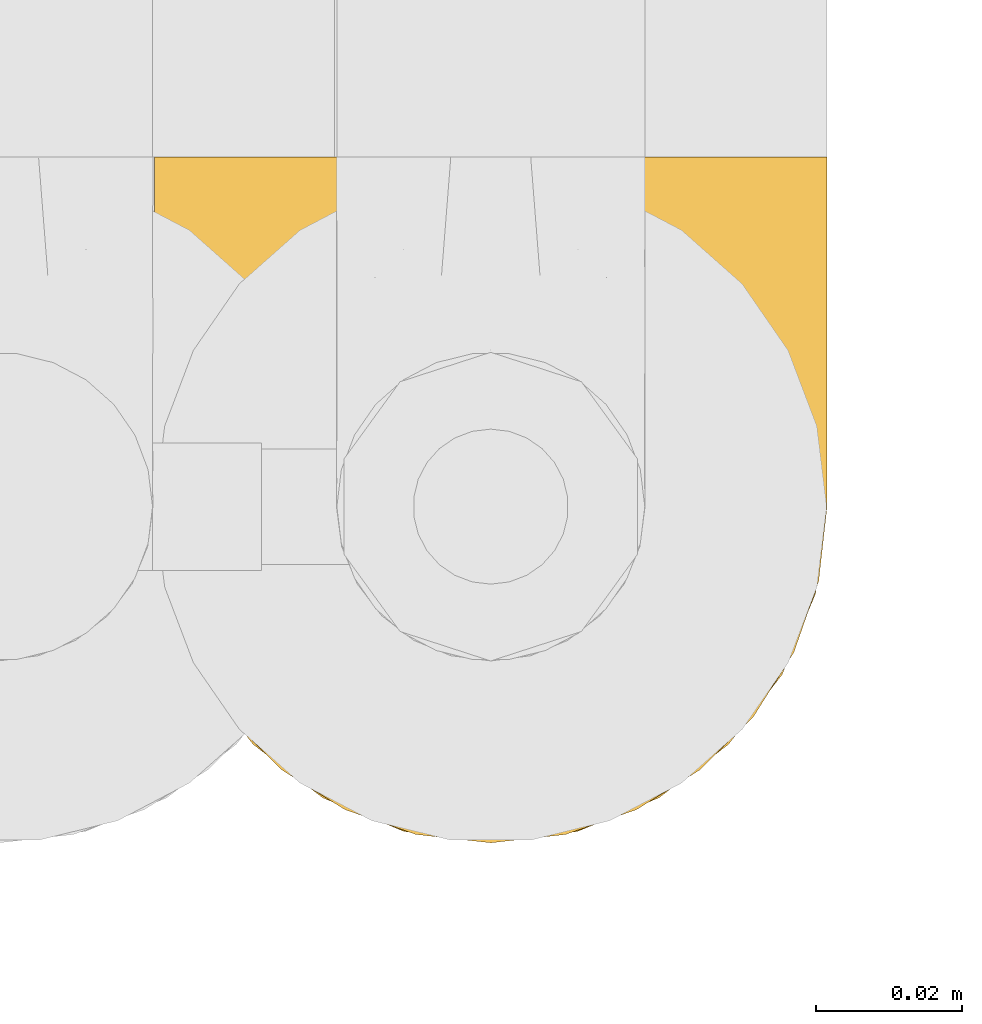
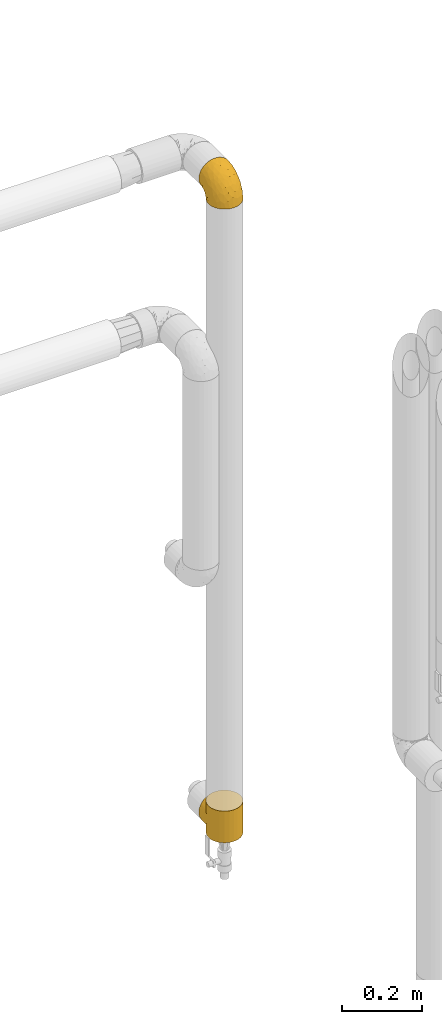
# One storey, part 318 of 827: 2 coverings.
"""IFC2X3 building model written with IfcOpenShell, lengths in millimetres."""

import ifcopenshell
import ifcopenshell.guid

model = None  # the IFC model being written
_history = None  # IfcOwnerHistory: only IFC2X3 demands one
_inside = {}  # id of a spatial element -> (the spatial element, [elements in it])
_under = {}  # id of a project, library or spatial element -> (it, [spatial elements below it])
_declared = {}  # id of a project -> (the project, [libraries it declares])
_typed = {}  # id of a type object -> (the type object, [elements of that type])
_made_of = {}  # id of a material, layer set ... -> (it, [elements and type objects made of it])


def new_model(schema):
    """Start an empty IFC model of exactly this schema.

    Asked for "IFC4X3", IfcOpenShell would pick the latest addendum, in which some entities
    have other attributes; the version numbers below select the first issue.
    IFC2X3 requires an IfcOwnerHistory on every rooted entity: one is made here for all.
    """
    global model, _history
    if schema == "IFC4X3":
        model = ifcopenshell.file(schema_version=(4, 3, 0, 0))
    else:
        model = ifcopenshell.file(schema=schema)
    _inside.clear()
    _under.clear()
    _declared.clear()
    _typed.clear()
    _made_of.clear()
    _history = None
    if model.schema == "IFC2X3":
        org = make("IfcOrganization", Name="unknown")
        user = make(
            "IfcPersonAndOrganization",
            ThePerson=make("IfcPerson", FamilyName="unknown"),
            TheOrganization=org,
        )
        app = make(
            "IfcApplication",
            ApplicationDeveloper=org,
            Version="unknown",
            ApplicationFullName="unknown",
            ApplicationIdentifier="unknown",
        )
        _history = make(
            "IfcOwnerHistory",
            OwningUser=user,
            OwningApplication=app,
            ChangeAction="ADDED",
            CreationDate=0,
        )
    return model


def make(cls, **values):
    """One entity of the class cls with the attributes given. An attribute that is None is left unset."""
    return model.create_entity(
        cls, **{name: value for name, value in values.items() if value is not None}
    )


def entity(cls, *values):
    """Any entity or typed value of the class cls, its attributes in the order of the schema. None: left unset."""
    e = model.create_entity(cls)
    for i, value in enumerate(values):
        if value is not None:
            e[i] = value
    return e


def rooted(cls, **values):
    """An entity with a GlobalId (a new one), such as an element, a storey or a relation."""
    return make(cls, GlobalId=ifcopenshell.guid.new(), OwnerHistory=_history, **values)


def si_unit(unit_type, name, prefix=None):
    """IfcSIUnit, for example si_unit("LENGTHUNIT", "METRE", prefix="MILLI")."""
    return make("IfcSIUnit", UnitType=unit_type, Prefix=prefix, Name=name)


def converted_unit(unit_type, name, factor, base, dimensions=None, offset=None):
    """IfcConversionBasedUnit, such as the inch: factor (a typed value) times the base unit."""
    return make(
        "IfcConversionBasedUnit"
        if offset is None
        else "IfcConversionBasedUnitWithOffset",
        ConversionOffset=offset,
        Dimensions=None
        if dimensions is None
        else entity("IfcDimensionalExponents", *dimensions),
        UnitType=unit_type,
        Name=name,
        ConversionFactor=make(
            "IfcMeasureWithUnit", ValueComponent=factor, UnitComponent=base
        ),
    )


def derived_unit(unit_type, elements):
    """IfcDerivedUnit: a product of units, each with its exponent."""
    return make(
        "IfcDerivedUnit",
        Elements=[
            make("IfcDerivedUnitElement", Unit=unit, Exponent=power)
            for unit, power in elements
        ],
        UnitType=unit_type,
    )


def assignment(units):
    """IfcUnitAssignment: the units of a project."""
    return None if units is None else make("IfcUnitAssignment", Units=units)


def point(xyz):
    """IfcCartesianPoint."""
    return None if xyz is None else make("IfcCartesianPoint", Coordinates=xyz)


def direction(xyz):
    """IfcDirection."""
    return None if xyz is None else make("IfcDirection", DirectionRatios=xyz)


def frame(location, z_axis=None, x_axis=None):
    """IfcAxis2Placement3D, a coordinate frame: its origin and axes. An axis left out is left unset."""
    return make(
        "IfcAxis2Placement3D",
        Location=point(location),
        Axis=direction(z_axis),
        RefDirection=direction(x_axis),
    )


def origin():
    """The frame at (0, 0, 0) with its axes left unset."""
    return frame((0.0, 0.0, 0.0))


def place(relative_to, where):
    """IfcLocalPlacement: puts the frame where relative to a parent placement (None: the world)."""
    return make(
        "IfcLocalPlacement", PlacementRelTo=relative_to, RelativePlacement=where
    )


def context(
    kind, dimensions, precision=None, world=None, true_north=None, identifier=None
):
    """IfcGeometricRepresentationContext, for example the 3D "Model" context."""
    return make(
        "IfcGeometricRepresentationContext",
        ContextIdentifier=identifier,
        ContextType=kind,
        CoordinateSpaceDimension=dimensions,
        Precision=precision,
        WorldCoordinateSystem=world,
        TrueNorth=true_north,
    )


def subcontext(parent, identifier, kind, view, scale=None):
    """IfcGeometricRepresentationSubContext, for example "Body" below "Model"."""
    return make(
        "IfcGeometricRepresentationSubContext",
        ContextIdentifier=identifier,
        ContextType=kind,
        ParentContext=parent,
        TargetScale=scale,
        TargetView=view,
    )


def project(units=None, contexts=None):
    """IfcProject with its units and contexts."""
    return rooted(
        "IfcProject",
        Name="project",
        RepresentationContexts=contexts,
        UnitsInContext=assignment(units),
    )


def spatial(cls, under=None, at=None, **own):
    """A site, building, storey or space (cls), placed at a placement, below another one or the project."""
    s = rooted(cls, ObjectPlacement=at, **own)
    if under is not None:
        _under.setdefault(under.id(), (under, []))[1].append(s)
    return s


def faces_of(points, faces, orient=None, outer=None):
    """IfcFace entities. A face is a list of loops; a loop is a list of indices into points, from 0.

    orient and outer hold one flag for each loop. By default every Orientation is true, the
    first loop of a face is its IfcFaceOuterBound and the others are IfcFaceBound.
    """
    made = []
    for i, loops in enumerate(faces):
        bounds = []
        for j, loop in enumerate(loops):
            is_outer = j == 0 if outer is None else outer[i][j]
            bounds.append(
                make(
                    "IfcFaceOuterBound" if is_outer else "IfcFaceBound",
                    Bound=make("IfcPolyLoop", Polygon=[points[k] for k in loop]),
                    Orientation=True if orient is None else orient[i][j],
                )
            )
        made.append(make("IfcFace", Bounds=bounds))
    return made


def faceted_brep(points, faces, orient=None, outer=None, voids=None):
    """IfcFacetedBrep: a solid bounded by flat faces; with voids (closed shells), ...WithVoids."""
    shared = [point(p) for p in points]
    hull = make("IfcClosedShell", CfsFaces=faces_of(shared, faces, orient, outer))
    if voids is None:
        return make("IfcFacetedBrep", Outer=hull)
    return make(
        "IfcFacetedBrepWithVoids",
        Outer=hull,
        Voids=[
            make(cls, CfsFaces=faces_of(shared, fs, o, b)) for cls, fs, o, b in voids
        ],
    )


def shape(context_of_items, identifier, shape_type, items):
    """IfcShapeRepresentation: the items that make up one representation, for example the "Body"."""
    return make(
        "IfcShapeRepresentation",
        ContextOfItems=context_of_items,
        RepresentationIdentifier=identifier,
        RepresentationType=shape_type,
        Items=items,
    )


def made_of(thing, what):
    """Note that an element or type object is made of a material, layer set ...; save() writes the relation."""
    if what is not None:
        _made_of.setdefault(what.id(), (what, []))[1].append(thing)
    return thing


def element(
    cls,
    number,
    at=None,
    inside=None,
    cuts=None,
    type_object=None,
    material=None,
    context=None,
    identifier="Body",
    shape_type=None,
    held_by="IfcProductDefinitionShape",
    body=None,
    shapes=None,
    **own,
):
    """One element of the class cls, such as IfcWall. Its Tag is "e" and its number.

    at: its placement. inside: the storey or other place that contains it. cuts: it is an
    opening in that element (IfcRelVoidsElement). A single representation is given by context,
    identifier, shape_type and body (its items); several are given by shapes. held_by: the class
    of the entity that holds the representations. save() writes the other relations.
    """
    e = rooted(cls, Tag="e%d" % number, ObjectPlacement=at, **own)
    if body is not None:
        shapes = [shape(context, identifier, shape_type, body)]
    if shapes is not None:
        e.Representation = make(held_by, Representations=shapes)
    if inside is not None:
        _inside.setdefault(inside.id(), (inside, []))[1].append(e)
    if cuts is not None:
        rooted(
            "IfcRelVoidsElement", RelatingBuildingElement=cuts, RelatedOpeningElement=e
        )
    if type_object is not None:
        _typed.setdefault(type_object.id(), (type_object, []))[1].append(e)
    return made_of(e, material)


def aggregate(whole, parts):
    """IfcRelAggregates: a whole, such as a stair, and the parts it consists of."""
    return rooted("IfcRelAggregates", RelatingObject=whole, RelatedObjects=parts)


def save(model, path):
    """Write the relations noted so far, then the file.

    IfcRelAggregates (storeys below a building ...), IfcRelContainedInSpatialStructure (elements
    in a storey), IfcRelDefinesByType, IfcRelAssociatesMaterial and IfcRelDeclares: one each for
    every whole, place, type object, material and project.
    """
    for whole, parts in _under.values():
        aggregate(whole, parts)
    for where, things in _inside.values():
        rooted(
            "IfcRelContainedInSpatialStructure",
            RelatedElements=things,
            RelatingStructure=where,
        )
    for kind, things in _typed.values():
        rooted("IfcRelDefinesByType", RelatedObjects=things, RelatingType=kind)
    for what, things in _made_of.values():
        rooted("IfcRelAssociatesMaterial", RelatedObjects=things, RelatingMaterial=what)
    for by, libraries in _declared.values():
        rooted("IfcRelDeclares", RelatingContext=by, RelatedDefinitions=libraries)
    model.write(path)


model = new_model("IFC2X3")

# Units and contexts
model_context = context("Model", 3, precision=0.01, world=origin(), true_north=direction((6.12303176911189e-17, 1.0)))
body_context = subcontext(model_context, "Body", "Model", "MODEL_VIEW")
ifc_project = project(units=[si_unit("LENGTHUNIT", "METRE", prefix="MILLI"), si_unit("AREAUNIT", "SQUARE_METRE"), si_unit("VOLUMEUNIT", "CUBIC_METRE"), converted_unit("PLANEANGLEUNIT", "DEGREE", entity("IfcRatioMeasure", 0.0174532925199433), si_unit("PLANEANGLEUNIT", "RADIAN"), dimensions=[0, 0, 0, 0, 0, 0, 0]), si_unit("MASSUNIT", "GRAM", prefix="KILO"), derived_unit("MASSDENSITYUNIT", [(si_unit("MASSUNIT", "GRAM", prefix="KILO"), 1), (si_unit("LENGTHUNIT", "METRE"), -3)]), derived_unit("MOMENTOFINERTIAUNIT", [(si_unit("LENGTHUNIT", "METRE"), 4)]), si_unit("TIMEUNIT", "SECOND"), si_unit("FREQUENCYUNIT", "HERTZ"), si_unit("THERMODYNAMICTEMPERATUREUNIT", "DEGREE_CELSIUS"), derived_unit("THERMALTRANSMITTANCEUNIT", [(si_unit("MASSUNIT", "GRAM", prefix="KILO"), 1), (si_unit("THERMODYNAMICTEMPERATUREUNIT", "KELVIN"), -1), (si_unit("TIMEUNIT", "SECOND"), -3)]), derived_unit("VOLUMETRICFLOWRATEUNIT", [(si_unit("LENGTHUNIT", "METRE"), 3), (si_unit("TIMEUNIT", "SECOND"), -1)]), derived_unit("MASSFLOWRATEUNIT", [(si_unit("MASSUNIT", "GRAM", prefix="KILO"), 1), (si_unit("TIMEUNIT", "SECOND"), -1)]), derived_unit("ROTATIONALFREQUENCYUNIT", [(si_unit("TIMEUNIT", "SECOND"), -1)]), si_unit("ELECTRICCURRENTUNIT", "AMPERE"), si_unit("ELECTRICVOLTAGEUNIT", "VOLT"), si_unit("POWERUNIT", "WATT"), si_unit("FORCEUNIT", "NEWTON", prefix="KILO"), si_unit("ILLUMINANCEUNIT", "LUX"), si_unit("LUMINOUSFLUXUNIT", "LUMEN"), si_unit("LUMINOUSINTENSITYUNIT", "CANDELA"), derived_unit("USERDEFINED", [(si_unit("MASSUNIT", "GRAM", prefix="KILO"), -1), (si_unit("LENGTHUNIT", "METRE"), -2), (si_unit("TIMEUNIT", "SECOND"), 3), (si_unit("LUMINOUSFLUXUNIT", "LUMEN"), 1)]), derived_unit("LINEARVELOCITYUNIT", [(si_unit("LENGTHUNIT", "METRE"), 1), (si_unit("TIMEUNIT", "SECOND"), -1)]), si_unit("PRESSUREUNIT", "PASCAL"), derived_unit("USERDEFINED", [(si_unit("LENGTHUNIT", "METRE"), -2), (si_unit("MASSUNIT", "GRAM", prefix="KILO"), 1), (si_unit("TIMEUNIT", "SECOND"), -2)]), derived_unit("LINEARFORCEUNIT", [(si_unit("MASSUNIT", "GRAM", prefix="KILO"), 1), (si_unit("LENGTHUNIT", "METRE"), 1), (si_unit("TIMEUNIT", "SECOND"), -2), (si_unit("LENGTHUNIT", "METRE"), -1)]), derived_unit("PLANARFORCEUNIT", [(si_unit("MASSUNIT", "GRAM", prefix="KILO"), 1), (si_unit("LENGTHUNIT", "METRE"), 1), (si_unit("TIMEUNIT", "SECOND"), -2), (si_unit("LENGTHUNIT", "METRE"), -2)])], contexts=[model_context])

# Site, building, storey
site_placement = place(None, origin())
site = spatial("IfcSite", under=ifc_project, at=site_placement, CompositionType="ELEMENT")
building_placement = place(site_placement, origin())
building = spatial("IfcBuilding", under=site, at=building_placement, CompositionType="ELEMENT")
storey_placement = place(building_placement, frame((0.0, 0.0, 28200.0)))
storey = spatial("IfcBuildingStorey", under=building, at=storey_placement, Name="08", CompositionType="ELEMENT", Elevation=28200.0)

# Coverings
covering_1_placement = place(storey_placement, frame((30594.41, 19295.64, 2250.4)))
element("IfcCovering", 1, at=covering_1_placement, inside=storey, Name=":ADSK_", ObjectType=":ADSK_", PredefinedType="INSULATION", context=body_context, shape_type="Brep", body=[
    faceted_brep([(83.91, 18.98, 1.6), (76.59, 11.67, 1.6), (67.83, 6.17, 1.6), (58.07, 2.75, 1.6), (47.8, 1.6, 1.6), (37.51, 2.75, 1.6), (27.74, 6.17, 1.6), (18.98, 11.68, 1.6), (11.67, 19.0, 1.6), (6.17, 27.76, 1.6), (2.75, 37.52, 1.6), (1.6, 47.8, 1.6), (2.06, 51.94, 1.6), (2.41, 55.01, 1.6), (2.75, 58.08, 1.6), (4.46, 62.96, 1.6), (6.17, 67.85, 1.6), (8.93, 72.23, 1.6), (11.68, 76.61, 1.6), (15.34, 80.26, 1.6), (19.0, 83.92, 1.6), (27.76, 89.42, 1.6), (32.64, 91.13, 1.6), (37.52, 92.84, 1.6), (47.8, 94.0, 1.6), (58.08, 92.84, 1.6), (62.96, 91.13, 1.6), (67.85, 89.42, 1.6), (76.61, 83.91, 1.6), (80.26, 80.25, 1.6), (83.92, 76.59, 1.6), (86.67, 72.21, 1.6), (89.42, 67.83, 1.6), (91.13, 62.95, 1.6), (92.84, 58.07, 1.6), (93.18, 55.0, 1.6), (93.53, 51.94, 1.6), (94.0, 47.8, 1.6), (92.84, 37.51, 1.6), (89.42, 27.74, 1.6), (47.8, 95.8, 3.4), (35.84, 95.8, 4.97), (24.7, 95.8, 9.58), (19.91, 95.8, 13.26), (15.13, 95.8, 16.93), (11.46, 95.8, 21.71), (7.78, 95.8, 26.5), (5.48, 95.8, 32.07), (3.17, 95.8, 37.64), (2.69, 95.8, 41.25), (2.42, 95.8, 43.34), (2.14, 95.8, 45.42), (1.6, 95.8, 49.6), (3.17, 95.8, 61.55), (7.78, 95.8, 72.7), (15.13, 95.8, 82.26), (24.7, 95.8, 89.61), (35.84, 95.8, 94.22), (47.8, 95.8, 95.8), (59.75, 95.8, 94.22), (70.9, 95.8, 89.61), (80.46, 95.8, 82.26), (87.81, 95.8, 72.7), (92.42, 95.8, 61.55), (94.0, 95.8, 49.6), (93.45, 95.8, 45.42), (92.9, 95.8, 41.25), (92.42, 95.8, 37.64), (90.11, 95.8, 32.07), (87.81, 95.8, 26.5), (84.13, 95.8, 21.71), (80.46, 95.8, 16.93), (75.68, 95.8, 13.26), (70.9, 95.8, 9.58), (59.75, 95.8, 4.97), (71.98, 60.58, 81.55), (63.6, 74.11, 90.4), (59.72, 51.59, 83.0), (47.8, 66.69, 91.18), (55.16, 76.19, 93.13), (47.8, 84.43, 94.0), (63.76, 31.2, 66.19), (72.22, 42.88, 70.92), (74.18, 79.41, 85.95), (92.52, 60.7, 49.74), (94.0, 61.85, 35.54), (94.0, 65.75, 38.14), (94.0, 69.64, 40.74), (94.0, 73.53, 43.34), (94.0, 77.43, 45.94), (82.14, 74.59, 77.59), (80.34, 54.72, 71.17), (87.52, 64.18, 65.81), (79.59, 37.94, 59.03), (78.25, 25.89, 45.85), (85.01, 34.73, 45.79), (90.25, 42.89, 41.42), (93.2, 49.83, 34.51), (87.23, 48.58, 56.04), (85.55, 22.41, 15.15), (93.0, 78.69, 56.51), (89.31, 81.64, 68.39), (61.31, 6.22, 23.33), (56.86, 12.11, 42.86), (68.34, 14.81, 39.42), (65.71, 21.61, 53.58), (56.99, 22.41, 59.17), (72.15, 30.12, 59.06), (70.34, 10.01, 22.63), (78.36, 15.36, 20.55), (47.8, 3.39, 12.96), (47.8, 19.59, 56.96), (47.8, 30.01, 67.38), (93.06, 41.19, 18.72), (94.0, 48.54, 5.33), (94.0, 49.28, 9.07), (94.0, 49.82, 11.79), (94.0, 50.37, 14.51), (94.0, 50.91, 17.24), (94.0, 51.45, 19.96), (89.88, 31.61, 21.03), (94.0, 80.15, 46.48), (94.0, 82.88, 47.03), (94.0, 85.6, 47.57), (94.0, 88.32, 48.11), (94.0, 90.19, 48.48), (94.0, 92.06, 48.85), (47.8, 6.21, 30.7), (94.0, 54.05, 23.86), (94.0, 56.65, 27.75), (94.0, 59.25, 31.64), (83.7, 24.66, 31.26), (47.8, 40.43, 77.8), (55.9, 35.17, 72.75), (47.8, 12.9, 43.83), (47.8, 53.56, 84.49), (81.75, 85.34, 14.58), (86.43, 78.44, 16.17), (79.8, 84.37, 10.82), (69.84, 89.05, 4.64), (79.5, 82.76, 7.71), (88.08, 86.31, 25.13), (91.6, 83.73, 32.66), (92.93, 77.31, 34.94), (92.43, 87.78, 36.76), (93.24, 87.91, 40.48), (93.36, 81.29, 39.25), (57.25, 93.97, 3.69), (89.41, 70.76, 13.99), (92.89, 63.67, 21.85), (92.66, 62.62, 17.93), (79.58, 90.64, 15.11), (86.51, 84.08, 21.14), (86.29, 76.28, 12.7), (83.91, 77.45, 7.21), (90.94, 88.72, 32.27), (91.94, 71.28, 25.68), (91.98, 68.09, 22.18), (82.79, 91.07, 18.79), (93.16, 57.47, 10.12), (88.76, 70.34, 9.47), (73.94, 91.35, 10.45), (91.89, 62.99, 11.29), (47.8, 94.52, 2.87), (92.22, 76.47, 31.16), (88.56, 69.96, 6.31), (87.72, 89.86, 25.62), (88.33, 78.94, 21.18), (92.18, 73.51, 28.81), (71.78, 89.62, 7.45), (9.09, 84.09, 21.14), (7.51, 86.3, 25.13), (12.8, 91.06, 18.79), (1.6, 88.32, 48.11), (1.6, 92.06, 48.85), (1.6, 82.88, 47.03), (1.6, 85.6, 47.57), (38.35, 93.97, 3.69), (23.84, 89.63, 7.44), (1.6, 50.37, 14.51), (1.6, 49.82, 11.79), (1.6, 48.54, 5.33), (1.6, 49.28, 9.07), (16.1, 82.77, 7.71), (6.84, 70.36, 9.47), (2.66, 77.31, 34.94), (3.37, 76.47, 31.16), (1.6, 69.64, 40.74), (1.6, 65.75, 38.14), (3.16, 87.78, 36.76), (2.35, 87.91, 40.48), (25.77, 89.06, 4.63), (16.02, 90.65, 15.11), (13.85, 85.35, 14.58), (1.6, 73.53, 43.34), (1.6, 77.43, 45.94), (2.23, 81.29, 39.25), (11.69, 77.46, 7.21), (9.31, 76.29, 12.69), (2.43, 57.47, 10.14), (2.71, 63.71, 21.81), (3.61, 68.11, 22.19), (6.18, 70.77, 14.0), (3.66, 71.31, 25.69), (9.17, 78.46, 16.17), (6.77, 69.52, 6.66), (2.93, 62.64, 17.92), (21.66, 91.35, 10.45), (1.6, 59.25, 31.64), (16.09, 84.6, 10.64), (3.7, 62.98, 11.31), (1.6, 51.45, 19.96), (1.6, 54.05, 23.86), (1.6, 56.65, 27.75), (3.99, 83.73, 32.66), (1.6, 80.15, 46.48), (4.65, 88.72, 32.27), (1.6, 61.85, 35.54), (3.43, 73.56, 28.77), (7.27, 78.96, 21.17), (9.46, 91.36, 23.36), (1.6, 50.91, 17.24), (2.4, 62.87, 47.58), (40.43, 76.19, 93.13), (13.57, 73.57, 77.44), (11.3, 56.07, 66.78), (18.65, 49.77, 71.68), (27.26, 44.73, 74.96), (23.61, 60.58, 81.55), (3.07, 47.64, 36.7), (2.69, 78.32, 56.9), (35.87, 51.59, 83.0), (31.99, 74.11, 90.4), (6.71, 76.04, 67.83), (21.41, 79.41, 85.95), (27.24, 14.82, 39.41), (34.26, 6.22, 23.33), (38.73, 12.12, 42.87), (26.97, 23.51, 53.92), (31.83, 31.2, 66.19), (23.4, 34.96, 64.12), (6.91, 33.86, 33.13), (3.4, 38.94, 23.1), (5.84, 30.23, 16.98), (35.73, 20.67, 55.72), (39.69, 35.17, 72.75), (17.6, 15.85, 23.77), (10.38, 22.59, 18.41), (20.6, 21.56, 43.7), (5.36, 55.94, 54.53), (24.84, 9.19, 17.73), (13.87, 25.79, 38.98), (9.06, 41.16, 50.28), (15.99, 37.95, 59.02)], [[[0, 1, 2, 3, 4, 5, 6, 7, 8, 9, 10, 11, 12, 13, 14, 15, 16, 17, 18, 19, 20, 21, 22, 23, 24, 25, 26, 27, 28, 29, 30, 31, 32, 33, 34, 35, 36, 37, 38, 39]], [[40, 41, 42, 43, 44, 45, 46, 47, 48, 49, 50, 51, 52, 53, 54, 55, 56, 57, 58, 59, 60, 61, 62, 63, 64, 65, 66, 67, 68, 69, 70, 71, 72, 73, 74]], [[75, 76, 77]], [[78, 79, 80]], [[77, 81, 82]], [[76, 75, 83]], [[84, 85, 86, 87, 88, 89]], [[90, 91, 92]], [[76, 60, 59]], [[93, 94, 95]], [[90, 62, 61]], [[83, 61, 60]], [[96, 97, 84]], [[98, 93, 95]], [[0, 39, 99]], [[100, 84, 89]], [[62, 101, 63]], [[2, 102, 3]], [[92, 84, 100]], [[103, 102, 104]], [[103, 105, 106]], [[93, 107, 94]], [[1, 108, 2]], [[92, 101, 90]], [[108, 1, 109]], [[102, 110, 3]], [[93, 82, 107]], [[102, 108, 104]], [[111, 106, 112]], [[109, 0, 99]], [[113, 37, 114, 115, 116, 117, 118, 119]], [[120, 38, 113]], [[100, 89, 121, 122, 123, 124, 125, 126, 64]], [[127, 102, 103]], [[97, 119, 128, 129, 130, 85]], [[99, 120, 131]], [[132, 133, 77]], [[59, 80, 79]], [[1, 0, 109]], [[98, 84, 92]], [[94, 109, 131]], [[120, 39, 38]], [[93, 91, 82]], [[104, 94, 105]], [[97, 113, 119]], [[95, 120, 96]], [[83, 90, 61]], [[91, 93, 98]], [[64, 63, 100]], [[100, 63, 101]], [[77, 76, 79]], [[133, 106, 81]], [[84, 97, 85]], [[113, 96, 120]], [[113, 97, 96]], [[37, 113, 38]], [[110, 102, 127]], [[110, 4, 3]], [[103, 111, 134, 127]], [[90, 75, 91]], [[82, 81, 107]], [[91, 75, 82]], [[77, 82, 75]], [[76, 83, 60]], [[90, 83, 75]], [[105, 107, 81]], [[94, 131, 95]], [[105, 94, 107]], [[109, 94, 104]], [[120, 95, 131]], [[98, 95, 96]], [[84, 98, 96]], [[98, 92, 91]], [[106, 105, 81]], [[103, 104, 105]], [[112, 106, 133]], [[103, 106, 111]], [[112, 133, 132]], [[81, 77, 133]], [[77, 78, 135, 132]], [[120, 99, 39]], [[109, 99, 131]], [[59, 58, 80]], [[59, 79, 76]], [[90, 101, 62]], [[100, 101, 92]], [[2, 108, 102]], [[109, 104, 108]], [[78, 77, 79]], [[136, 137, 138]], [[27, 139, 140]], [[141, 142, 143]], [[144, 145, 121]], [[146, 89, 88]], [[147, 139, 25]], [[148, 149, 150]], [[136, 151, 152]], [[147, 40, 74]], [[24, 147, 25]], [[140, 153, 154]], [[33, 116, 34]], [[73, 72, 151]], [[114, 37, 36, 35, 34, 116, 115]], [[146, 155, 144]], [[156, 85, 130]], [[157, 149, 148]], [[151, 158, 152]], [[117, 33, 159]], [[29, 154, 160]], [[161, 74, 73]], [[162, 128, 119]], [[66, 65, 64, 126, 125, 124, 123, 122, 67]], [[163, 147, 24]], [[27, 140, 28]], [[149, 129, 150]], [[139, 27, 26, 25]], [[68, 144, 69]], [[129, 128, 150]], [[164, 87, 86]], [[130, 129, 149]], [[122, 145, 67]], [[154, 153, 148]], [[162, 119, 159]], [[165, 30, 160]], [[150, 160, 148]], [[128, 162, 150]], [[30, 165, 31]], [[145, 144, 68]], [[89, 146, 144]], [[87, 164, 143]], [[166, 155, 142]], [[88, 87, 143]], [[162, 160, 150]], [[160, 30, 29]], [[154, 29, 28]], [[140, 154, 28]], [[160, 154, 148]], [[140, 137, 153]], [[157, 148, 153]], [[156, 130, 157]], [[153, 137, 157]], [[157, 137, 156]], [[167, 137, 136]], [[168, 85, 156]], [[152, 168, 167]], [[167, 168, 156]], [[164, 152, 141]], [[71, 158, 72]], [[152, 167, 136]], [[88, 142, 146]], [[144, 155, 69]], [[146, 142, 155]], [[70, 166, 71]], [[142, 141, 166]], [[70, 69, 155]], [[141, 158, 71]], [[161, 73, 151]], [[138, 137, 140]], [[161, 136, 169]], [[136, 161, 151]], [[74, 161, 169]], [[152, 158, 141]], [[151, 72, 158]], [[168, 152, 164]], [[137, 167, 156]], [[164, 86, 168]], [[85, 168, 86]], [[116, 33, 117]], [[130, 149, 157]], [[67, 145, 68]], [[121, 89, 144]], [[145, 122, 121]], [[40, 147, 163]], [[169, 147, 74]], [[159, 33, 32]], [[162, 159, 32]], [[159, 119, 118, 117]], [[139, 147, 169]], [[139, 169, 138]], [[162, 32, 31]], [[141, 143, 164]], [[88, 143, 142]], [[71, 166, 141]], [[155, 166, 70]], [[139, 138, 140]], [[169, 136, 138]], [[160, 162, 165]], [[162, 31, 165]], [[170, 171, 172]], [[173, 174, 52, 51, 50, 49, 48, 175, 176]], [[177, 178, 41]], [[179, 15, 180]], [[12, 11, 181, 182, 180, 14, 13]], [[183, 21, 20]], [[19, 18, 184]], [[185, 186, 187]], [[186, 188, 187]], [[43, 172, 44]], [[189, 190, 47]], [[23, 22, 21, 191]], [[170, 192, 193]], [[40, 163, 177]], [[194, 195, 196]], [[24, 23, 177]], [[197, 198, 183]], [[199, 15, 179]], [[47, 46, 189]], [[200, 201, 202]], [[201, 203, 204]], [[205, 206, 184]], [[207, 41, 178]], [[16, 15, 199]], [[14, 180, 15]], [[202, 201, 198]], [[208, 201, 200]], [[163, 24, 177]], [[48, 47, 190]], [[196, 195, 189]], [[197, 184, 202]], [[204, 193, 209]], [[210, 211, 212]], [[206, 212, 213]], [[205, 17, 210]], [[184, 206, 202]], [[210, 212, 206]], [[185, 194, 214]], [[189, 215, 190]], [[216, 45, 214]], [[186, 171, 170]], [[189, 216, 196]], [[197, 20, 19]], [[194, 185, 187]], [[197, 183, 20]], [[184, 197, 19]], [[197, 202, 198]], [[206, 200, 202]], [[204, 183, 198]], [[201, 208, 203]], [[203, 208, 217]], [[204, 198, 201]], [[217, 188, 218]], [[193, 219, 170]], [[171, 186, 185]], [[170, 218, 186]], [[170, 219, 218]], [[42, 207, 192]], [[171, 220, 172]], [[216, 189, 46]], [[214, 194, 196]], [[44, 220, 45]], [[214, 196, 216]], [[216, 46, 45]], [[214, 45, 220]], [[192, 43, 42]], [[204, 203, 219]], [[207, 193, 192]], [[209, 193, 178]], [[41, 207, 42]], [[193, 207, 178]], [[43, 192, 172]], [[170, 172, 192]], [[204, 219, 193]], [[219, 203, 218]], [[217, 218, 203]], [[188, 186, 218]], [[206, 213, 200]], [[208, 200, 213]], [[199, 210, 16]], [[215, 189, 195]], [[215, 175, 190]], [[175, 48, 190]], [[199, 179, 221, 211]], [[210, 199, 211]], [[23, 191, 177]], [[40, 177, 41]], [[178, 177, 191]], [[21, 183, 191]], [[209, 191, 183]], [[205, 18, 17]], [[17, 16, 210]], [[171, 185, 214]], [[172, 220, 44]], [[214, 220, 171]], [[191, 209, 178]], [[204, 209, 183]], [[206, 205, 210]], [[18, 205, 184]], [[222, 195, 194, 187, 188, 217]], [[57, 223, 80]], [[224, 225, 226]], [[226, 227, 228]], [[229, 217, 208, 213, 212, 211]], [[230, 52, 174, 173, 176, 175, 215, 195]], [[231, 232, 228]], [[231, 78, 223]], [[223, 57, 232]], [[224, 233, 225]], [[233, 54, 53]], [[234, 232, 56]], [[56, 55, 234]], [[234, 224, 228]], [[235, 236, 237]], [[224, 55, 54]], [[238, 239, 240]], [[52, 230, 53]], [[241, 242, 243]], [[239, 244, 245]], [[11, 10, 242]], [[236, 6, 5]], [[7, 246, 8]], [[8, 247, 9]], [[238, 248, 235]], [[222, 229, 249]], [[242, 211, 221, 179, 180, 182, 181, 11]], [[233, 53, 230]], [[111, 112, 244]], [[250, 6, 236]], [[247, 251, 241]], [[6, 250, 7]], [[127, 236, 110]], [[249, 229, 252]], [[247, 8, 246]], [[235, 246, 250]], [[236, 5, 110]], [[235, 244, 238]], [[237, 236, 127]], [[243, 9, 247]], [[252, 229, 241]], [[56, 232, 57]], [[222, 230, 195]], [[225, 249, 252]], [[249, 233, 230]], [[54, 233, 224]], [[231, 228, 227]], [[245, 132, 231]], [[249, 225, 233]], [[226, 225, 253]], [[235, 250, 236]], [[246, 7, 250]], [[251, 247, 246]], [[243, 247, 241]], [[248, 246, 235]], [[252, 251, 253]], [[229, 222, 217]], [[230, 222, 249]], [[5, 4, 110]], [[237, 127, 134, 111]], [[238, 244, 239]], [[224, 234, 55]], [[232, 234, 228]], [[242, 241, 229]], [[10, 9, 243]], [[211, 242, 229]], [[10, 243, 242]], [[80, 223, 78]], [[80, 58, 57]], [[231, 223, 232]], [[227, 240, 239]], [[224, 226, 228]], [[240, 226, 253]], [[227, 239, 245]], [[226, 240, 227]], [[251, 248, 253]], [[240, 253, 248]], [[244, 235, 237]], [[237, 111, 244]], [[132, 245, 112]], [[112, 245, 244]], [[135, 78, 231, 132]], [[227, 245, 231]], [[248, 238, 240]], [[246, 248, 251]], [[251, 252, 241]], [[225, 252, 253]]]),
])
covering_2_placement = place(storey_placement, frame((30594.41, 19295.64, 327.0)))
element("IfcCovering", 2, at=covering_2_placement, inside=storey, Name=":ADSK_", ObjectType=":ADSK_", PredefinedType="INSULATION", context=body_context, shape_type="Brep", body=[
    faceted_brep([(2.11, 54.7, 54.91), (1.6, 47.8, 96.0), (3.17, 59.75, 96.0), (25.36, 87.94, 88.15), (27.48, 88.96, 96.0), (29.21, 90.09, 90.3), (7.78, 70.9, 96.0), (6.34, 68.19, 68.4), (10.15, 74.57, 74.78), (15.13, 80.46, 96.0), (24.7, 87.81, 96.0), (35.84, 92.42, 96.0), (37.01, 92.61, 92.82), (35.9, 92.25, 92.46), (33.67, 91.53, 91.74), (1.6, 47.8, 48.0), (2.11, 54.7, 41.09), (1.6, 47.8, 0.0), (38.13, 92.97, 93.18), (37.33, 92.62, 96.0), (38.83, 92.81, 96.0), (3.68, 61.53, 61.74), (44.06, 93.5, 96.0), (44.81, 93.6, 96.0), (44.17, 93.61, 93.82), (43.31, 93.4, 96.0), (21.52, 85.79, 86.0), (19.91, 84.13, 96.0), (33.05, 91.27, 96.0), (31.44, 90.81, 91.02), (30.27, 90.11, 96.0), (46.3, 93.8, 96.0), (46.59, 93.87, 94.07), (45.38, 93.74, 93.94), (42.96, 93.48, 93.69), (40.32, 93.01, 96.0), (41.82, 93.21, 96.0), (40.54, 93.23, 93.43), (15.18, 80.52, 80.72), (39.33, 93.1, 93.3), (41.75, 93.36, 93.56), (47.8, 94.0, 96.0), (47.8, 94.0, 94.2), (47.8, 94.0, 0.0), (46.59, 93.87, 1.93), (47.8, 94.0, 1.8), (45.55, 93.7, 96.0), (61.93, 91.53, 91.73), (59.75, 92.42, 96.0), (62.54, 91.27, 96.0), (52.28, 93.4, 96.0), (53.77, 93.21, 96.0), (52.64, 93.48, 93.69), (59.7, 92.25, 92.45), (58.59, 92.61, 92.81), (65.32, 90.11, 96.0), (66.38, 90.09, 90.3), (64.16, 90.81, 91.02), (57.48, 92.97, 93.17), (56.76, 92.81, 96.0), (58.26, 92.62, 96.0), (68.11, 88.96, 96.0), (70.9, 87.81, 96.0), (70.23, 87.94, 88.15), (74.07, 85.8, 86.0), (75.68, 84.13, 96.0), (80.41, 80.52, 80.73), (50.22, 93.74, 93.94), (49.29, 93.8, 96.0), (50.04, 93.7, 96.0), (50.78, 93.6, 96.0), (80.46, 80.46, 96.0), (85.44, 74.58, 74.79), (87.81, 70.9, 96.0), (55.06, 93.23, 93.43), (53.85, 93.35, 93.56), (89.25, 68.2, 68.4), (92.42, 59.75, 96.0), (56.27, 93.1, 93.3), (55.27, 93.01, 96.0), (93.48, 54.7, 54.91), (94.0, 47.8, 96.0), (91.9, 61.54, 61.74), (94.0, 47.8, 48.0), (93.48, 54.7, 41.09), (94.0, 47.8, 0.0), (49.01, 93.87, 94.07), (51.43, 93.61, 93.82), (51.53, 93.5, 96.0), (49.01, 93.87, 1.93), (70.9, 7.78, 0.0), (59.75, 3.17, 0.0), (47.8, 1.6, 0.0), (35.84, 3.17, 0.0), (24.7, 7.78, 0.0), (15.13, 15.13, 0.0), (7.78, 24.7, 0.0), (3.17, 35.84, 0.0), (3.17, 59.75, 0.0), (7.78, 70.9, 0.0), (15.13, 80.46, 0.0), (19.91, 84.13, 0.0), (24.7, 87.81, 0.0), (27.48, 88.96, 0.0), (30.27, 90.11, 0.0), (33.05, 91.27, 0.0), (35.84, 92.42, 0.0), (37.33, 92.62, 0.0), (38.83, 92.81, 0.0), (40.32, 93.01, 0.0), (41.82, 93.21, 0.0), (43.31, 93.4, 0.0), (44.06, 93.5, 0.0), (44.81, 93.6, 0.0), (45.55, 93.7, 0.0), (46.3, 93.8, 0.0), (49.29, 93.8, 0.0), (50.04, 93.7, 0.0), (50.78, 93.6, 0.0), (51.53, 93.5, 0.0), (52.28, 93.4, 0.0), (53.77, 93.21, 0.0), (55.27, 93.01, 0.0), (56.76, 92.81, 0.0), (58.26, 92.62, 0.0), (59.75, 92.42, 0.0), (62.54, 91.27, 0.0), (65.32, 90.11, 0.0), (68.11, 88.96, 0.0), (70.9, 87.81, 0.0), (75.68, 84.13, 0.0), (80.46, 80.46, 0.0), (87.81, 70.9, 0.0), (92.42, 59.75, 0.0), (92.42, 35.84, 0.0), (87.81, 24.7, 0.0), (80.46, 15.13, 0.0), (3.17, 35.84, 96.0), (7.78, 24.7, 96.0), (15.13, 15.13, 96.0), (24.7, 7.78, 96.0), (35.84, 3.17, 96.0), (47.8, 1.6, 96.0), (59.75, 3.17, 96.0), (70.9, 7.78, 96.0), (80.46, 15.13, 96.0), (87.81, 24.7, 96.0), (92.42, 35.84, 96.0), (33.67, 91.53, 4.26), (35.9, 92.25, 3.54), (37.01, 92.61, 3.18), (3.68, 61.53, 34.26), (6.34, 68.19, 27.6), (29.21, 90.09, 5.7), (39.33, 93.1, 2.7), (40.54, 93.23, 2.57), (10.15, 74.57, 21.22), (21.52, 85.79, 10.0), (25.36, 87.94, 7.85), (15.18, 80.52, 15.28), (31.44, 90.81, 4.98), (38.13, 92.97, 2.82), (45.38, 93.74, 2.06), (41.75, 93.36, 2.44), (42.96, 93.48, 2.31), (44.17, 93.61, 2.18), (66.38, 90.09, 5.7), (64.16, 90.81, 4.98), (74.07, 85.8, 10.0), (55.06, 93.23, 2.57), (80.41, 80.52, 15.27), (70.23, 87.94, 7.85), (56.27, 93.1, 2.7), (57.48, 92.97, 2.83), (51.43, 93.61, 2.18), (52.64, 93.48, 2.31), (61.93, 91.53, 4.27), (58.59, 92.61, 3.19), (59.7, 92.25, 3.55), (89.25, 68.2, 27.6), (91.9, 61.54, 34.26), (85.44, 74.58, 21.21), (53.85, 93.35, 2.44), (50.22, 93.74, 2.06), (1.6, 95.8, 48.0), (3.17, 95.8, 59.96), (7.78, 95.8, 71.1), (15.13, 95.8, 80.67), (19.91, 95.8, 84.34), (24.7, 95.8, 88.01), (27.48, 95.8, 89.16), (30.27, 95.8, 90.32), (33.05, 95.8, 91.47), (35.84, 95.8, 92.63), (37.33, 95.8, 92.82), (38.83, 95.8, 93.02), (40.32, 95.8, 93.22), (41.82, 95.8, 93.41), (43.31, 95.8, 93.61), (44.06, 95.8, 93.71), (44.81, 95.8, 93.81), (45.55, 95.8, 93.9), (46.3, 95.8, 94.0), (47.8, 95.8, 94.2), (49.29, 95.8, 94.0), (50.04, 95.8, 93.9), (50.78, 95.8, 93.81), (51.53, 95.8, 93.71), (52.28, 95.8, 93.61), (53.77, 95.8, 93.41), (55.27, 95.8, 93.22), (56.76, 95.8, 93.02), (58.26, 95.8, 92.82), (59.75, 95.8, 92.63), (62.54, 95.8, 91.47), (65.32, 95.8, 90.32), (68.11, 95.8, 89.16), (70.9, 95.8, 88.01), (75.68, 95.8, 84.34), (80.46, 95.8, 80.67), (87.81, 95.8, 71.1), (92.42, 95.8, 59.96), (94.0, 95.8, 48.0), (92.42, 95.8, 36.04), (87.81, 95.8, 24.9), (80.46, 95.8, 15.33), (75.68, 95.8, 11.66), (70.9, 95.8, 7.99), (68.11, 95.8, 6.84), (65.32, 95.8, 5.68), (62.54, 95.8, 4.53), (59.75, 95.8, 3.37), (58.26, 95.8, 3.18), (56.76, 95.8, 2.98), (55.27, 95.8, 2.78), (53.77, 95.8, 2.59), (52.28, 95.8, 2.39), (51.53, 95.8, 2.29), (50.78, 95.8, 2.19), (50.04, 95.8, 2.1), (49.29, 95.8, 2.0), (47.8, 95.8, 1.8), (46.3, 95.8, 2.0), (45.55, 95.8, 2.1), (44.81, 95.8, 2.19), (44.06, 95.8, 2.29), (43.31, 95.8, 2.39), (41.82, 95.8, 2.59), (40.32, 95.8, 2.78), (38.83, 95.8, 2.98), (37.33, 95.8, 3.18), (35.84, 95.8, 3.37), (33.05, 95.8, 4.53), (30.27, 95.8, 5.68), (27.48, 95.8, 6.84), (24.7, 95.8, 7.99), (19.91, 95.8, 11.66), (15.13, 95.8, 15.33), (7.78, 95.8, 24.9), (3.17, 95.8, 36.04)], [[[0, 1, 2]], [[3, 4, 5]], [[2, 6, 7]], [[8, 6, 9]], [[4, 3, 10]], [[8, 7, 6]], [[11, 12, 13, 14]], [[0, 15, 1]], [[15, 16, 17]], [[18, 19, 20]], [[7, 21, 2]], [[0, 2, 21]], [[19, 18, 12]], [[12, 11, 19]], [[22, 23, 24, 25]], [[26, 27, 10]], [[28, 29, 30]], [[28, 11, 14]], [[31, 32, 33]], [[29, 28, 14]], [[34, 25, 24]], [[35, 36, 37]], [[38, 9, 27]], [[38, 27, 26]], [[5, 30, 29]], [[20, 39, 18]], [[5, 4, 30]], [[26, 10, 3]], [[35, 39, 20]], [[9, 38, 8]], [[36, 34, 40, 37]], [[34, 36, 25]], [[39, 35, 37]], [[32, 41, 42]], [[43, 44, 45]], [[23, 33, 24]], [[33, 23, 46, 31]], [[41, 32, 31]], [[47, 48, 49]], [[50, 51, 52]], [[48, 47, 53, 54]], [[55, 56, 57]], [[58, 59, 60]], [[61, 62, 63]], [[49, 57, 47]], [[58, 60, 54]], [[64, 62, 65]], [[66, 64, 65]], [[61, 63, 56]], [[67, 68, 69, 70]], [[65, 71, 66]], [[62, 64, 63]], [[72, 71, 73]], [[51, 74, 75, 52]], [[76, 73, 77]], [[78, 79, 59]], [[59, 58, 78]], [[80, 77, 81]], [[79, 78, 74]], [[76, 72, 73]], [[80, 82, 77]], [[83, 80, 81]], [[84, 83, 85]], [[56, 55, 61]], [[76, 77, 82]], [[57, 49, 55]], [[48, 54, 60]], [[71, 72, 66]], [[74, 51, 79]], [[86, 41, 68]], [[87, 50, 52]], [[70, 87, 67]], [[50, 87, 70, 88]], [[41, 86, 42]], [[89, 43, 45]], [[68, 67, 86]], [[90, 91, 92, 93, 94, 95, 96, 97, 17, 98, 99, 100, 101, 102, 103, 104, 105, 106, 107, 108, 109, 110, 111, 112, 113, 114, 115, 43, 116, 117, 118, 119, 120, 121, 122, 123, 124, 125, 126, 127, 128, 129, 130, 131, 132, 133, 85, 134, 135, 136]], [[1, 137, 138, 139, 140, 141, 142, 143, 144, 145, 146, 147, 81, 77, 73, 71, 65, 62, 61, 55, 49, 48, 60, 59, 79, 51, 50, 88, 70, 69, 68, 41, 31, 46, 23, 22, 25, 36, 35, 20, 19, 11, 28, 30, 4, 10, 27, 9, 6, 2]], [[140, 139, 95, 94]], [[92, 142, 141, 93]], [[141, 140, 94, 93]], [[96, 138, 137, 97]], [[1, 15, 17, 97, 137]], [[95, 139, 138, 96]], [[106, 148, 149, 150]], [[151, 152, 98]], [[153, 104, 103]], [[148, 106, 105]], [[16, 151, 98]], [[109, 154, 155]], [[17, 16, 98]], [[99, 156, 100]], [[99, 98, 152]], [[156, 99, 152]], [[102, 157, 158]], [[106, 150, 107]], [[155, 110, 109]], [[157, 101, 159]], [[105, 160, 148]], [[161, 107, 150]], [[162, 115, 114, 113]], [[157, 102, 101]], [[153, 103, 158]], [[104, 153, 160]], [[159, 101, 100]], [[102, 158, 103]], [[108, 161, 154]], [[110, 155, 163, 164]], [[164, 111, 110]], [[161, 108, 107]], [[160, 105, 104]], [[159, 100, 156]], [[154, 109, 108]], [[44, 43, 115]], [[165, 111, 164]], [[113, 165, 162]], [[111, 165, 113, 112]], [[115, 162, 44]], [[166, 127, 167]], [[166, 128, 127]], [[129, 168, 130]], [[122, 121, 169]], [[170, 130, 168]], [[171, 168, 129]], [[123, 172, 173]], [[119, 118, 174, 120]], [[128, 171, 129]], [[174, 175, 120]], [[126, 125, 176]], [[171, 128, 166]], [[170, 131, 130]], [[125, 177, 178, 176]], [[179, 180, 133]], [[173, 124, 123]], [[177, 125, 124]], [[180, 84, 133]], [[131, 181, 132]], [[181, 131, 170]], [[179, 132, 181]], [[179, 133, 132]], [[121, 175, 182, 169]], [[167, 126, 176]], [[84, 85, 133]], [[126, 167, 127]], [[122, 172, 123]], [[124, 173, 177]], [[116, 89, 183]], [[175, 121, 120]], [[172, 122, 169]], [[118, 183, 174]], [[183, 118, 117, 116]], [[43, 89, 116]], [[83, 81, 147, 134, 85]], [[134, 147, 146, 135]], [[146, 145, 136, 135]], [[136, 145, 144, 90]], [[90, 144, 143, 91]], [[91, 143, 142, 92]], [[184, 185, 186, 187, 188, 189, 190, 191, 192, 193, 194, 195, 196, 197, 198, 199, 200, 201, 202, 203, 204, 205, 206, 207, 208, 209, 210, 211, 212, 213, 214, 215, 216, 217, 218, 219, 220, 221, 222, 223, 224, 225, 226, 227, 228, 229, 230, 231, 232, 233, 234, 235, 236, 237, 238, 239, 240, 241, 242, 243, 244, 245, 246, 247, 248, 249, 250, 251, 252, 253, 254, 255, 256, 257, 258, 259]], [[39, 196, 195]], [[198, 197, 34]], [[193, 14, 13, 12]], [[5, 191, 190]], [[14, 193, 192]], [[190, 189, 3]], [[192, 29, 14]], [[18, 194, 12]], [[26, 189, 188]], [[38, 26, 188]], [[190, 3, 5]], [[33, 202, 201, 200]], [[188, 187, 38]], [[189, 26, 3]], [[8, 187, 186]], [[29, 192, 191]], [[7, 186, 185]], [[193, 12, 194]], [[0, 185, 184]], [[191, 5, 29]], [[7, 8, 186]], [[197, 37, 40, 34]], [[0, 21, 185]], [[15, 0, 184]], [[18, 195, 194]], [[7, 185, 21]], [[196, 39, 37]], [[187, 8, 38]], [[37, 197, 196]], [[195, 18, 39]], [[32, 203, 202]], [[24, 198, 34]], [[200, 24, 33]], [[198, 24, 200, 199]], [[203, 32, 42]], [[202, 33, 32]], [[16, 184, 259]], [[158, 254, 153]], [[259, 258, 152]], [[156, 258, 257]], [[254, 158, 255]], [[156, 152, 258]], [[251, 150, 149, 148]], [[16, 15, 184]], [[161, 250, 249]], [[152, 151, 259]], [[16, 259, 151]], [[250, 161, 150]], [[150, 251, 250]], [[245, 244, 165, 246]], [[157, 256, 255]], [[252, 160, 253]], [[252, 251, 148]], [[242, 44, 162]], [[160, 252, 148]], [[164, 246, 165]], [[248, 247, 155]], [[159, 257, 256]], [[159, 256, 157]], [[153, 253, 160]], [[249, 154, 161]], [[153, 254, 253]], [[157, 255, 158]], [[248, 154, 249]], [[257, 159, 156]], [[247, 164, 163, 155]], [[164, 247, 246]], [[154, 248, 155]], [[44, 241, 45]], [[244, 162, 165]], [[162, 244, 243, 242]], [[241, 44, 242]], [[176, 231, 230]], [[236, 235, 175]], [[231, 176, 178, 177]], [[229, 166, 167]], [[173, 233, 232]], [[228, 227, 171]], [[230, 167, 176]], [[173, 232, 177]], [[168, 227, 226]], [[170, 168, 226]], [[228, 171, 166]], [[183, 240, 239, 238]], [[226, 225, 170]], [[227, 168, 171]], [[181, 225, 224]], [[235, 169, 182, 175]], [[179, 224, 223]], [[172, 234, 233]], [[233, 173, 172]], [[84, 223, 222]], [[234, 172, 169]], [[179, 181, 224]], [[84, 180, 223]], [[83, 84, 222]], [[166, 229, 228]], [[179, 223, 180]], [[167, 230, 229]], [[231, 177, 232]], [[225, 181, 170]], [[169, 235, 234]], [[89, 241, 240]], [[174, 236, 175]], [[238, 174, 183]], [[236, 174, 238, 237]], [[241, 89, 45]], [[240, 183, 89]], [[80, 222, 221]], [[209, 52, 75, 74]], [[221, 220, 76]], [[72, 220, 219]], [[210, 78, 211]], [[72, 76, 220]], [[63, 216, 56]], [[80, 83, 222]], [[54, 213, 212]], [[76, 82, 221]], [[80, 221, 82]], [[58, 212, 211]], [[216, 63, 217]], [[207, 206, 87, 208]], [[64, 218, 217]], [[204, 86, 67]], [[214, 213, 47]], [[57, 214, 47]], [[212, 58, 54]], [[52, 208, 87]], [[210, 209, 74]], [[66, 219, 218]], [[66, 218, 64]], [[56, 215, 57]], [[211, 78, 58]], [[56, 216, 215]], [[64, 217, 63]], [[213, 54, 53, 47]], [[219, 66, 72]], [[214, 57, 215]], [[52, 209, 208]], [[78, 210, 74]], [[86, 203, 42]], [[206, 67, 87]], [[67, 206, 205, 204]], [[203, 86, 204]]]),
])

save(model, "model.ifc")
